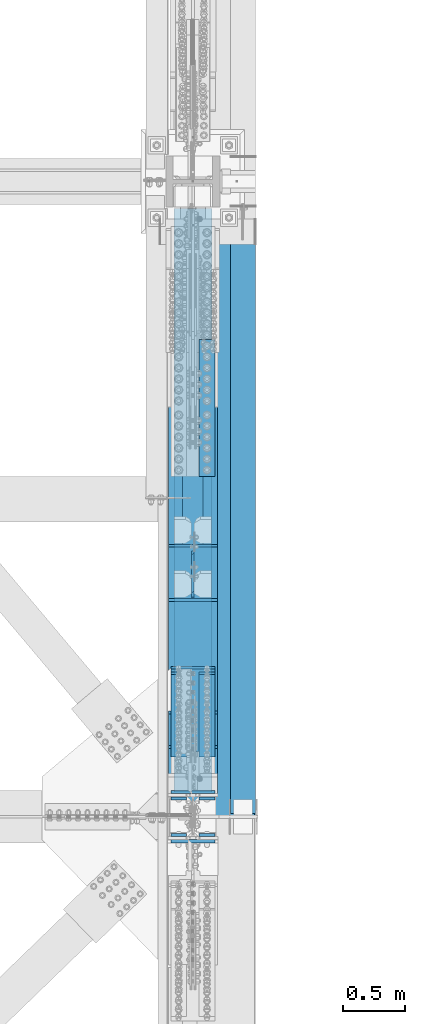
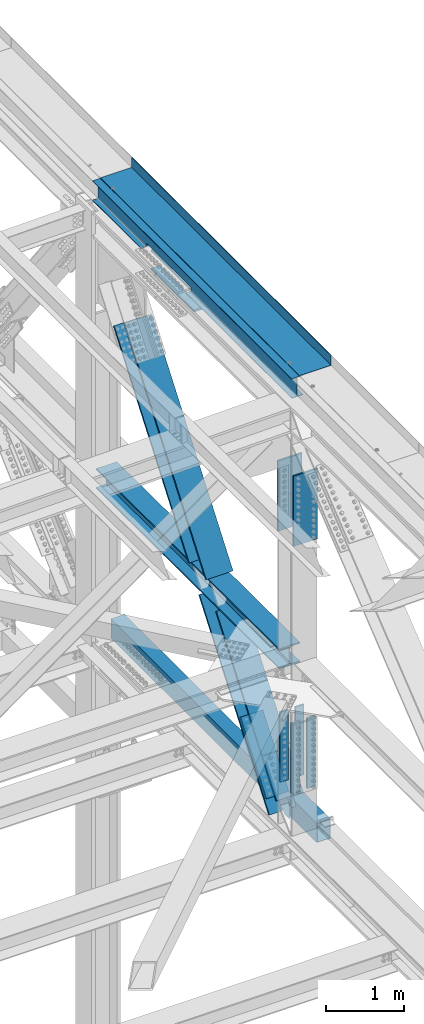
# One storey, part 1986 of 3843: 12 beams, 6 members, 8 elements without a shape of their own.
"""IFC2X3 building model written with IfcOpenShell, lengths in millimetres."""

from ifc_helpers import new_model, si_unit, frame, origin_with_axes, place, context, subcontext, project, spatial, faceted_brep, material, type_object, element, aggregate, save


model = new_model("IFC2X3")

# Units and contexts
model_context = context("Model", 3, precision=1e-05, world=origin_with_axes())
body_context = subcontext(model_context, "Body", "Model", "MODEL_VIEW")
ifc_project = project(units=[si_unit("LENGTHUNIT", "METRE", prefix="MILLI"), si_unit("AREAUNIT", "SQUARE_METRE"), si_unit("VOLUMEUNIT", "CUBIC_METRE"), si_unit("MASSUNIT", "GRAM", prefix="KILO"), si_unit("TIMEUNIT", "SECOND"), si_unit("PLANEANGLEUNIT", "RADIAN"), si_unit("SOLIDANGLEUNIT", "STERADIAN"), si_unit("THERMODYNAMICTEMPERATUREUNIT", "DEGREE_CELSIUS"), si_unit("LUMINOUSINTENSITYUNIT", "LUMEN")], contexts=[model_context])

# Site, building, storey
site_placement = place(None, origin_with_axes())
site = spatial("IfcSite", under=ifc_project, at=site_placement, CompositionType="ELEMENT")
building_placement = place(site_placement, origin_with_axes())
building = spatial("IfcBuilding", under=site, at=building_placement, Name="Undefined", CompositionType="ELEMENT")
storey_placement = place(building_placement, origin_with_axes())
storey = spatial("IfcBuildingStorey", under=building, at=storey_placement, Name="Undefined", CompositionType="ELEMENT", Elevation=0.0)

# Assembly, beam
assembly_1_placement = place(storey_placement, origin_with_axes())
assembly_1 = element("IfcElementAssembly", 1, at=assembly_1_placement, inside=storey, Name="BEAM", AssemblyPlace="NOTDEFINED", PredefinedType="RIGID_FRAME")
ifc_material_1 = material(Name="STEEL/A992")
beam_type_1 = type_object("IfcBeamType", Name="W12X26", PredefinedType="NOTDEFINED")
beam_1_placement = place(assembly_1_placement, frame((85648.8000000029, 83985.1, 46612.1750000001), z_axis=(0.0, 0.0, 1.0), x_axis=(0.0, 1.0, 0.0)))
beam_1 = element("IfcBeam", 2, at=beam_1_placement, type_object=beam_type_1, material=ifc_material_1, Name="BEAM", ObjectType="W12X26", context=body_context, shape_type="Brep", body=[
    faceted_brep([(2724.15000000001, -3.17500000000291, -146.050000000003), (2724.15000000001, -82.5500000000029, -146.050000000003), (2724.15000000001, -82.5500000000029, -155.574999999997), (2724.15000000001, 82.5500000000029, -155.574999999997), (2724.15000000001, 82.5500000000029, -146.050000000003), (2724.15000000001, 3.17500000000291, -146.050000000003), (2724.15000000002, 3.17500000000291, -92.0750000001062), (2724.15000000002, -3.17500000000291, -92.0750000001062), (3879.85000000002, -3.17500000000291, -92.0750000001062), (3879.85000000002, 3.17500000000291, -92.0750000001062), (3879.85000000002, 3.17500000000291, -146.050000000003), (3879.85000000002, 82.5500000000029, -146.050000000003), (3879.85000000001, 82.5500000000029, -155.574999999997), (3879.85000000001, -82.5500000000029, -155.574999999997), (3879.85000000002, -82.5500000000029, -146.050000000003), (3879.85000000002, -3.17500000000291, -146.050000000003), (0.0, -82.5500000000029, 155.574999999997), (0.0, -82.5500000000029, 146.050000000003), (5130.8, -82.5500000000029, 146.050000000003), (5130.8, -82.5500000000029, 155.574999999997), (0.0, 82.5500000000029, 155.574999999997), (5130.8, 82.5500000000029, 155.574999999997), (0.0, 82.5500000000029, 146.050000000003), (5130.8, 82.5500000000029, 146.050000000003), (0.0, 3.17500000000291, 146.050000000003), (5130.8, 3.17500000000291, 146.050000000003), (0.0, -82.5500000000029, -155.574999999997), (0.0, -82.5500000000029, -146.050000000003), (0.0, -3.17500000000291, -146.050000000003), (0.0, -3.17500000000291, 146.050000000003), (0.0, 3.17500000000291, -146.050000000003), (0.0, 82.5500000000029, -146.050000000003), (0.0, 82.5500000000029, -155.574999999997), (5130.8, -3.17500000000291, 146.050000000003), (5130.8, 3.17500000000291, -146.050000000003), (5130.8, -3.17500000000291, -146.050000000003), (5130.8, -82.5500000000029, -146.050000000003), (5130.8, -82.5500000000029, -155.574999999997), (5130.8, 82.5500000000029, -155.574999999997), (5130.8, 82.5500000000029, -146.050000000003)], [[[0, 1, 2, 3, 4, 5, 6, 7]], [[8, 9, 10, 11, 12, 13, 14, 15]], [[7, 6, 9, 8]], [[16, 17, 18, 19]], [[20, 16, 19, 21]], [[22, 20, 21, 23]], [[24, 22, 23, 25]], [[26, 27, 28, 29, 17, 16, 20, 22, 24, 30, 31, 32]], [[17, 29, 33, 18]], [[34, 25, 23, 21, 19, 18, 33, 35, 36, 37, 38, 39]], [[36, 35, 15, 14]], [[37, 36, 14, 13]], [[38, 37, 13, 12]], [[39, 38, 12, 11]], [[34, 39, 11, 10]], [[5, 30, 24, 25, 34, 10, 9, 6]], [[31, 30, 5, 4]], [[32, 31, 4, 3]], [[26, 32, 3, 2]], [[27, 26, 2, 1]], [[28, 27, 1, 0]], [[35, 33, 29, 28, 0, 7, 8, 15]]]),
])

assembly_2_placement = place(storey_placement, origin_with_axes())
assembly_2 = element("IfcElementAssembly", 3, at=assembly_2_placement, inside=storey, Name="BEAM", AssemblyPlace="NOTDEFINED", PredefinedType="RIGID_FRAME")
ifc_material_2 = material()
beam_type_2 = type_object("IfcBeamType", Name="HSS12X8X3/8", PredefinedType="NOTDEFINED")
beam_2_placement = place(assembly_2_placement, frame((86055.2000000001, 89319.1000000233, 39477.9500004064), z_axis=(0.0, 0.0, 1.0), x_axis=(0.0, -1.0, 0.0)))
beam_2 = element("IfcBeam", 4, at=beam_2_placement, type_object=beam_type_2, material=ifc_material_2, Name="BEAM", ObjectType="HSS12X8X3/8", context=body_context, shape_type="Brep", body=[
    faceted_brep([(6.35000000002037, 92.0749999999971, -142.875), (6.35000000002037, -92.0749999999971, -142.875), (5308.60000038189, -92.0749999999971, -142.875), (5308.60000038189, 92.0749999999971, -142.875), (6.35000000002037, -92.0749999999971, 142.875), (5308.60000038189, -92.0749999999971, 142.875), (6.35000000002037, 92.0749999999971, 142.875), (5308.60000038189, 92.0749999999971, 142.875), (6.35000000002037, 101.600000000006, -152.400000000001), (6.35000000002037, 101.600000000006, 152.400000000001), (5308.60000038189, 101.600000000006, 152.400000000001), (5308.60000038189, 101.600000000006, -152.400000000001), (6.35000000002037, -101.600000000006, 152.400000000001), (5308.60000038189, -101.600000000006, 152.400000000001), (6.35000000002037, -101.600000000006, -152.400000000001), (5308.60000038189, -101.600000000006, -152.400000000001)], [[[0, 1, 2, 3]], [[1, 4, 5, 2]], [[4, 6, 7, 5]], [[6, 0, 3, 7]], [[8, 9, 10, 11]], [[9, 12, 13, 10]], [[12, 14, 15, 13]], [[14, 8, 11, 15]], [[13, 15, 11, 10], [5, 7, 3, 2]], [[14, 12, 9, 8], [6, 4, 1, 0]]]),
])
aggregate(assembly_2, [beam_2])

# Assembly, beams
assembly_3_placement = place(storey_placement, origin_with_axes())
assembly_3 = element("IfcElementAssembly", 5, at=assembly_3_placement, inside=storey, Name="COLUMN", AssemblyPlace="NOTDEFINED", PredefinedType="RIGID_FRAME")
ifc_material_3 = material(Name="STEEL/A572-50")
beam_type_3 = type_object("IfcBeamType", PredefinedType="NOTDEFINED")
beam_3_placement = place(assembly_3_placement, frame((85763.1, 86732.984456283, 46115.7277416579), z_axis=(-1.0, 0.0, 0.0), x_axis=(0.0, 0.999988750778627, -0.00474323899895545)))
beam_3 = element("IfcBeam", 6, at=beam_3_placement, type_object=beam_type_3, material=ifc_material_3, Name="PLATE", context=body_context, shape_type="Brep", body=[
    faceted_brep([(8.73114913702011e-11, 15.8750000000073, -63.5), (8.73114913702011e-11, 15.8750000000073, 63.5), (1104.89999997285, 15.8750000015862, 63.5), (1104.89999997285, 15.8750000015862, -63.5), (-1.01863406598568e-10, -15.8750000000146, 63.5), (1104.89999997268, -15.8749999984284, 63.5), (-1.01863406598568e-10, -15.8750000000146, -63.5), (1104.89999997268, -15.8749999984284, -63.5)], [[[0, 1, 2, 3]], [[1, 4, 5, 2]], [[4, 6, 7, 5]], [[6, 0, 3, 7]], [[5, 7, 3, 2]], [[6, 4, 1, 0]]]),
])
beam_4_placement = place(assembly_3_placement, frame((85763.1, 86734.354633894, 46404.5940936941), z_axis=(-1.0, 0.0, 0.0), x_axis=(0.0, 0.999988750778627, -0.00474323899895545)))
beam_4 = element("IfcBeam", 7, at=beam_4_placement, type_object=beam_type_3, material=ifc_material_3, Name="PLATE", context=body_context, shape_type="Brep", body=[
    faceted_brep([(8.73114913702011e-11, 15.8750000000073, -63.5), (8.73114913702011e-11, 15.8750000000073, 63.5), (1104.89999997285, 15.8750000015862, 63.5), (1104.89999997285, 15.8750000015862, -63.5), (-1.01863406598568e-10, -15.8750000000146, 63.5), (1104.89999997268, -15.8749999984284, 63.5), (-1.01863406598568e-10, -15.8750000000146, -63.5), (1104.89999997268, -15.8749999984284, -63.5)], [[[0, 1, 2, 3]], [[1, 4, 5, 2]], [[4, 6, 7, 5]], [[6, 0, 3, 7]], [[5, 7, 3, 2]], [[6, 4, 1, 0]]]),
])
aggregate(assembly_3, [beam_3, beam_4])

# Assembly, members, beams
assembly_4_placement = place(storey_placement, origin_with_axes())
assembly_4 = element("IfcElementAssembly", 8, at=assembly_4_placement, inside=storey, Name="BEAM", AssemblyPlace="NOTDEFINED", PredefinedType="RIGID_FRAME")
member_type_1 = type_object("IfcMemberType", PredefinedType="NOTDEFINED")
member_1_placement = place(assembly_4_placement, frame((85534.5, 85144.65330628, 40781.2415149889), z_axis=(1.0, 0.0, 0.0), x_axis=(0.0, -0.605220451019692, -0.796057916025914)))
member_1 = element("IfcMember", 9, at=member_1_placement, type_object=member_type_1, material=ifc_material_3, Name="PLATE", context=body_context, shape_type="Brep", body=[
    faceted_brep([(-4.36557456851006e-11, 12.7000000000116, -63.5), (-4.36557456851006e-11, 12.7000000000116, 63.5), (1104.90000001677, 12.7000000017251, 63.5), (1104.90000001677, 12.7000000017251, -63.5), (1.45519152283669e-11, -12.700000000008, 63.5), (1104.90000001682, -12.6999999982909, 63.5), (1.45519152283669e-11, -12.700000000008, -63.5), (1104.90000001682, -12.6999999982909, -63.5)], [[[0, 1, 2, 3]], [[1, 4, 5, 2]], [[4, 6, 7, 5]], [[6, 0, 3, 7]], [[5, 7, 3, 2]], [[6, 4, 1, 0]]]),
])
member_2_placement = place(assembly_4_placement, frame((85763.1, 85144.65330628, 40781.2415149889), z_axis=(1.0, 0.0, 0.0), x_axis=(0.0, -0.605220451019692, -0.796057916025914)))
member_2 = element("IfcMember", 10, at=member_2_placement, type_object=member_type_1, material=ifc_material_3, Name="PLATE", context=body_context, shape_type="Brep", body=[
    faceted_brep([(-4.36557456851006e-11, 12.7000000000116, -63.5), (-4.36557456851006e-11, 12.7000000000116, 63.5), (1104.90000001677, 12.7000000017251, 63.5), (1104.90000001677, 12.7000000017251, -63.5), (1.45519152283669e-11, -12.700000000008, 63.5), (1104.90000001682, -12.6999999982909, 63.5), (1.45519152283669e-11, -12.700000000008, -63.5), (1104.90000001682, -12.6999999982909, -63.5)], [[[0, 1, 2, 3]], [[1, 4, 5, 2]], [[4, 6, 7, 5]], [[6, 0, 3, 7]], [[5, 7, 3, 2]], [[6, 4, 1, 0]]]),
])
member_type_2 = type_object("IfcMemberType", PredefinedType="NOTDEFINED")
member_3_placement = place(assembly_4_placement, frame((85648.8, 84520.1761979037, 39868.0495622531), z_axis=(1.0, 0.0, 0.0), x_axis=(0.0, 0.605220451019692, 0.796057916025914)))
member_3 = element("IfcMember", 11, at=member_3_placement, type_object=member_type_2, material=ifc_material_3, Name="PLATE", context=body_context, shape_type="Brep", body=[
    faceted_brep([(-1.45519152283669e-11, 12.7000000000025, -177.800000000003), (-1.45519152283669e-11, 12.7000000000025, 177.800000000003), (1104.90000001682, 12.7000000017051, 177.800000000003), (1104.90000001682, 12.7000000017051, -177.800000000003), (4.36557456851006e-11, -12.7000000000171, 177.800000000003), (1104.90000001686, -12.6999999983072, 177.800000000003), (4.36557456851006e-11, -12.7000000000171, -177.800000000003), (1104.90000001686, -12.6999999983072, -177.800000000003)], [[[0, 1, 2, 3]], [[1, 4, 5, 2]], [[4, 6, 7, 5]], [[6, 0, 3, 7]], [[5, 7, 3, 2]], [[6, 4, 1, 0]]]),
])
beam_type_4 = type_object("IfcBeamType", PredefinedType="NOTDEFINED")
beam_5_placement = place(assembly_4_placement, frame((85763.1, 83837.462692029, 41479.6131557466), z_axis=(-1.0, 0.0, 0.0), x_axis=(0.0, 0.0, -1.0)))
beam_5 = element("IfcBeam", 12, at=beam_5_placement, type_object=beam_type_4, material=ifc_material_3, Name="PLATE", context=body_context, shape_type="Brep", body=[
    faceted_brep([(-4.36557456851006e-11, 12.7000000000116, -63.5), (-4.36557456851006e-11, 12.7000000000116, 63.5), (1104.90000001677, 12.7000000017251, 63.5), (1104.90000001677, 12.7000000017251, -63.5), (1.45519152283669e-11, -12.700000000008, 63.5), (1104.90000001682, -12.6999999982909, 63.5), (1.45519152283669e-11, -12.700000000008, -63.5), (1104.90000001682, -12.6999999982909, -63.5)], [[[0, 1, 2, 3]], [[1, 4, 5, 2]], [[4, 6, 7, 5]], [[6, 0, 3, 7]], [[5, 7, 3, 2]], [[6, 4, 1, 0]]]),
])
beam_6_placement = place(assembly_4_placement, frame((85763.1, 84132.7376189964, 41479.613127104), z_axis=(-1.0, 0.0, 0.0), x_axis=(0.0, 0.0, -1.0)))
beam_6 = element("IfcBeam", 13, at=beam_6_placement, type_object=beam_type_4, material=ifc_material_3, Name="PLATE", context=body_context, shape_type="Brep", body=[
    faceted_brep([(-4.36557456851006e-11, 12.7000000000116, -63.5), (-4.36557456851006e-11, 12.7000000000116, 63.5), (1104.90000001677, 12.7000000017251, 63.5), (1104.90000001677, 12.7000000017251, -63.5), (1.45519152283669e-11, -12.700000000008, 63.5), (1104.90000001682, -12.6999999982909, 63.5), (1.45519152283669e-11, -12.700000000008, -63.5), (1104.90000001682, -12.6999999982909, -63.5)], [[[0, 1, 2, 3]], [[1, 4, 5, 2]], [[4, 6, 7, 5]], [[6, 0, 3, 7]], [[5, 7, 3, 2]], [[6, 4, 1, 0]]]),
])
beam_7_placement = place(assembly_4_placement, frame((85534.5, 83837.462692029, 41479.6131557466), z_axis=(-1.0, 0.0, 0.0), x_axis=(0.0, 0.0, -1.0)))
beam_7 = element("IfcBeam", 14, at=beam_7_placement, type_object=beam_type_4, material=ifc_material_3, Name="PLATE", context=body_context, shape_type="Brep", body=[
    faceted_brep([(-4.36557456851006e-11, 12.7000000000116, -63.5), (-4.36557456851006e-11, 12.7000000000116, 63.5), (1104.90000001677, 12.7000000017251, 63.5), (1104.90000001677, 12.7000000017251, -63.5), (1.45519152283669e-11, -12.700000000008, 63.5), (1104.90000001682, -12.6999999982909, 63.5), (1.45519152283669e-11, -12.700000000008, -63.5), (1104.90000001682, -12.6999999982909, -63.5)], [[[0, 1, 2, 3]], [[1, 4, 5, 2]], [[4, 6, 7, 5]], [[6, 0, 3, 7]], [[5, 7, 3, 2]], [[6, 4, 1, 0]]]),
])
beam_8_placement = place(assembly_4_placement, frame((85534.5, 84132.7376189964, 41479.613127104), z_axis=(-1.0, 0.0, 0.0), x_axis=(0.0, 0.0, -1.0)))
beam_8 = element("IfcBeam", 15, at=beam_8_placement, type_object=beam_type_4, material=ifc_material_3, Name="PLATE", context=body_context, shape_type="Brep", body=[
    faceted_brep([(-4.36557456851006e-11, 12.7000000000116, -63.5), (-4.36557456851006e-11, 12.7000000000116, 63.5), (1104.90000001677, 12.7000000017251, 63.5), (1104.90000001677, 12.7000000017251, -63.5), (1.45519152283669e-11, -12.700000000008, 63.5), (1104.90000001682, -12.6999999982909, 63.5), (1.45519152283669e-11, -12.700000000008, -63.5), (1104.90000001682, -12.6999999982909, -63.5)], [[[0, 1, 2, 3]], [[1, 4, 5, 2]], [[4, 6, 7, 5]], [[6, 0, 3, 7]], [[5, 7, 3, 2]], [[6, 4, 1, 0]]]),
])

# Assembly, beams
assembly_5_placement = place(storey_placement, origin_with_axes())
assembly_5 = element("IfcElementAssembly", 16, at=assembly_5_placement, inside=storey, Name="BEAM", AssemblyPlace="NOTDEFINED", PredefinedType="RIGID_FRAME")
beam_type_5 = type_object("IfcBeamType", PredefinedType="NOTDEFINED")
beam_9_placement = place(assembly_5_placement, frame((85648.8, 83786.6625000003, 45397.5980310956), z_axis=(1.0, 0.0, 0.0), x_axis=(0.0, 0.0, -1.0)))
beam_9 = element("IfcBeam", 17, at=beam_9_placement, type_object=beam_type_5, material=ifc_material_3, Name="PLATE", context=body_context, shape_type="Brep", body=[
    faceted_brep([(-1.45519152283669e-11, 12.7000000000025, -177.800000000003), (-1.45519152283669e-11, 12.7000000000025, 177.800000000003), (1104.90000001682, 12.7000000017051, 177.800000000003), (1104.90000001682, 12.7000000017051, -177.800000000003), (4.36557456851006e-11, -12.7000000000171, 177.800000000003), (1104.90000001686, -12.6999999983072, 177.800000000003), (4.36557456851006e-11, -12.7000000000171, -177.800000000003), (1104.90000001686, -12.6999999983072, -177.800000000003)], [[[0, 1, 2, 3]], [[1, 4, 5, 2]], [[4, 6, 7, 5]], [[6, 0, 3, 7]], [[5, 7, 3, 2]], [[6, 4, 1, 0]]]),
])
beam_10_placement = place(assembly_5_placement, frame((85648.8, 84183.5375000118, 45397.5980310956), z_axis=(1.0, 0.0, 0.0), x_axis=(0.0, 0.0, -1.0)))
beam_10 = element("IfcBeam", 18, at=beam_10_placement, type_object=beam_type_5, material=ifc_material_3, Name="PLATE", context=body_context, shape_type="Brep", body=[
    faceted_brep([(-1.45519152283669e-11, 12.7000000000025, -177.800000000003), (-1.45519152283669e-11, 12.7000000000025, 177.800000000003), (1104.90000001682, 12.7000000017051, 177.800000000003), (1104.90000001682, 12.7000000017051, -177.800000000003), (4.36557456851006e-11, -12.7000000000171, 177.800000000003), (1104.90000001686, -12.6999999983072, 177.800000000003), (4.36557456851006e-11, -12.7000000000171, -177.800000000003), (1104.90000001686, -12.6999999983072, -177.800000000003)], [[[0, 1, 2, 3]], [[1, 4, 5, 2]], [[4, 6, 7, 5]], [[6, 0, 3, 7]], [[5, 7, 3, 2]], [[6, 4, 1, 0]]]),
])
aggregate(assembly_5, [beam_9, beam_10])

# Assembly, member
assembly_6_placement = place(storey_placement, origin_with_axes())
assembly_6 = element("IfcElementAssembly", 19, at=assembly_6_placement, inside=storey, Name="V. BRACE", AssemblyPlace="NOTDEFINED", PredefinedType="RIGID_FRAME")
member_type_3 = type_object("IfcMemberType", Name="W14X159", PredefinedType="NOTDEFINED")
member_4_placement = place(assembly_6_placement, frame((85648.8, 84692.7712675286, 40430.8125536112), z_axis=(0.0, -0.796057916025909, 0.605220451019698), x_axis=(0.0, 0.605220451019692, 0.796057916025914)))
member_4 = element("IfcMember", 20, at=member_4_placement, type_object=member_type_3, material=ifc_material_1, Name="V. BRACE", ObjectType="W14X159", context=body_context, shape_type="Brep", body=[
    faceted_brep([(2216.51898587827, -198.4375, -160.337505577176), (2216.51898792338, -198.4375, -190.499999997424), (2216.51898792338, 198.4375, -190.499999997424), (2216.51898587827, 198.4375, -160.337499997389), (2216.51898587827, 9.52499999999418, -160.337499997389), (2216.51898587827, -9.52499999999418, -160.33750494507), (1921.91877837267, 9.52499999999418, 160.337500002788), (6.34999999323918, 9.52499999999418, 160.337499999503), (6.34999999323918, 198.4375, 160.337499999503), (1921.91877837267, 198.4375, 160.337500002788), (1953.79543739048, 198.4375, 160.337500002825), (1953.79543739048, 9.52499999999418, 160.337500002825), (2165.71898587717, -9.52499999999418, -160.33749999744), (2165.71898587717, 9.52499999999418, -160.33749999744), (2148.37322655409, 9.52500024769688, -137.522306666513), (2148.37322655409, -9.52500000753207, -137.522306666513), (2146.47397907326, 9.52500024808978, -132.664781957996), (2146.47397907326, -9.52500000751752, -132.664781957996), (2147.41767368457, 9.52500024918118, -127.535247108899), (2147.41767368457, -9.52500000748842, -127.535247108899), (2150.92135800864, 9.52500025066547, -123.671714600365), (2150.92135800864, -9.52500000744476, -123.671714600365), (2155.93450594929, 9.52500025209156, -122.23260549664), (2155.93450594929, -9.5250000074011, -122.23260549664), (2187.7862577316, -9.52500008967763, -122.16180728731), (2163.97914469577, 9.52500044213957, -122.214724344565), (1979.7514455374, 9.52500066497305, 122.440016041743), (2003.65120365832, -9.52499986696057, 122.369900247009), (1927.63438812691, -9.52499999431893, 123.319637304914), (1924.54820041938, -9.52499999433348, 125.397968494013), (1922.49370009138, -9.52499999431893, 128.500071570961), (1921.78438772046, -9.52499999428983, 132.152590025158), (1921.91877837267, -9.52499999999418, 160.337500002788), (6.34999999323918, -9.52499999999418, 160.337499999503), (6.34999999470892, -9.52499999999418, -160.337499999619), (1931.28133526347, -9.52499999428983, 122.582214983027), (1921.91877837267, -198.4375, 160.337500002788), (6.34999999323918, -198.4375, 160.337499999503), (1953.79543739048, -9.52499999999418, 160.337500002825), (1953.79543739048, -198.4375, 160.337500002825), (6.34999999309366, -198.4375, 190.499999999422), (1953.79543541165, -198.4375, 190.499976563988), (6.34999999309366, 198.4375, 190.499999999422), (1953.79543541165, 198.4375, 190.500000002881), (1921.78438772046, 9.52500026060443, 132.152590025158), (1922.49370009138, 9.52500026022608, 128.500071570961), (1924.54820041938, 9.52500026024063, 125.397968494013), (1927.63438812691, 9.52500026064808, 123.319637304914), (1931.28133526347, 9.52500026136113, 122.582214983027), (6.34999999470892, 9.52499999999418, -160.337499999619), (6.34999999483989, -198.4375, -190.499999999538), (6.34999999470892, -198.4375, -160.337499999619), (6.34999999470892, 198.4375, -160.337499999619), (6.34999999483989, 198.4375, -190.499999999538), (2165.71898587717, -198.4375, -160.33749999744), (2165.71898587717, 198.4375, -160.33749999744)], [[[0, 1, 2, 3, 4, 5]], [[6, 7, 8, 9, 10, 11]], [[12, 13, 14, 15]], [[15, 14, 16, 17]], [[17, 16, 18, 19]], [[19, 18, 20, 21]], [[21, 20, 22, 23]], [[24, 23, 22, 25]], [[24, 25, 26, 27]], [[28, 29, 30, 31, 32, 33, 34, 12, 15, 17, 19, 21, 23, 24, 27, 35]], [[36, 37, 33, 32, 38, 39]], [[40, 37, 36, 39, 41]], [[42, 40, 41, 43]], [[9, 8, 42, 43, 10]], [[41, 39, 38, 11, 10, 43]], [[32, 6, 11, 38]], [[31, 44, 6, 32]], [[30, 45, 44, 31]], [[29, 46, 45, 30]], [[28, 47, 46, 29]], [[35, 48, 47, 28]], [[27, 26, 48, 35]], [[25, 22, 20, 18, 16, 14, 13, 49, 7, 6, 44, 45, 46, 47, 48, 26]], [[50, 51, 34, 33, 37, 40, 42, 8, 7, 49, 52, 53]], [[12, 34, 51, 54, 0, 5]], [[13, 12, 5, 4]], [[55, 52, 49, 13, 4, 3]], [[53, 52, 55, 3, 2]], [[50, 53, 2, 1]], [[54, 51, 50, 1, 0]]]),
])
aggregate(assembly_6, [member_4])

assembly_7_placement = place(storey_placement, origin_with_axes())
assembly_7 = element("IfcElementAssembly", 21, at=assembly_7_placement, inside=storey, Name="V. BRACE", AssemblyPlace="NOTDEFINED", PredefinedType="RIGID_FRAME")
member_5_placement = place(assembly_7_placement, frame((85648.8, 86083.8681444708, 42260.54860778), z_axis=(0.0, -0.796057916025909, 0.605220451019698), x_axis=(0.0, 0.605220451019692, 0.796057916025914)))
member_5 = element("IfcMember", 22, at=member_5_placement, type_object=member_type_3, material=ifc_material_1, Name="V. BRACE", ObjectType="W14X159", context=body_context, shape_type="Brep", body=[
    faceted_brep([(346.147679184418, -198.4375, -160.337476070046), (346.147679184418, -9.52499999999418, -160.337499999827), (346.147679184418, 9.52499999999418, -160.337499999827), (346.147679184418, 198.4375, -160.337499999827), (346.147699241148, 198.4375, -190.499999999884), (346.147699241148, -198.4375, -190.499999999884), (132.098386285114, 198.4375, 160.337500000453), (3549.85244767601, 198.4375, 160.337500004905), (3549.85244767601, 9.52499999999418, 160.337500004905), (132.098386285114, 9.52499999999418, 160.337500000453), (81.9632190665288, 9.52499999999418, 160.33750000038), (81.9632190665288, 198.4375, 160.33750000038), (3549.85244767599, 198.4375, 190.500000004962), (81.758154095849, 198.4375, 190.500000000429), (3549.85244767599, -198.4375, 190.500000004962), (81.758154095849, -198.4375, 190.496298616927), (132.098386285114, -198.4375, 160.337500000453), (3549.85244767601, -198.4375, 160.337500004905), (81.9632190665288, -198.4375, 160.33750000038), (132.098386285114, -9.52499999999418, 160.337500000453), (3549.85244767601, -9.52499999999418, 160.337500004905), (81.9632190665288, -9.52499999999418, 160.33750000038), (149.591664698572, 9.52500025652989, 137.51508667232), (149.591664698572, -9.52499999999418, 137.51508667232), (151.519125286926, 9.52500025690824, 132.63829633424), (151.519125286926, -9.52499999999418, 132.63829633424), (3549.85244767601, 9.52499999999418, -160.337499995636), (374.248942408507, 9.52499999999418, -160.33749999979), (391.805508776568, 9.52500023611356, -137.523687888744), (393.735538690235, 9.5250002353423, -132.653920581892), (392.798806802108, 9.52500023493485, -127.500069355847), (389.278624429804, 9.52500023503671, -123.620898676912), (384.239658548817, 9.52500023558969, -122.189650291497), (318.626834977593, 9.52500064445485, -122.308865874656), (134.491836521542, 9.52500042173779, 122.222767799874), (141.992705379351, 9.52500025960035, 122.186010390782), (147.041004904444, 9.52500025871268, 123.604763444098), (150.573353469983, 9.5250002577086, 127.480418476865), (391.805508776568, -9.52499999999418, -137.523687888744), (374.248942408507, -9.52499999999418, -160.33749999979), (393.735538690235, -9.52499999999418, -132.653920581892), (392.798806802108, -9.52499999999418, -127.500069355847), (389.278624429804, -9.52499999999418, -123.620898676912), (384.239658548817, -9.52499999999418, -122.189650291497), (294.831584718922, -9.52499999999418, -122.352100786396), (110.575777947059, -9.52499999999418, 122.339966535808), (141.992705379351, -9.52499999999418, 122.186010390782), (147.041004904444, -9.52499999999418, 123.604763444098), (150.573353469983, -9.52499999999418, 127.480418476865), (3549.85244767601, -9.52499999999418, -160.337499995636), (3549.85244767601, -198.4375, -160.337499995636), (3549.85244767599, -198.4375, -190.499999995693), (3549.85244767599, 198.4375, -190.499999995693), (3549.85244767601, 198.4375, -160.337499995636), (374.248942408507, -198.4375, -160.33749999979), (374.248942408507, 198.4375, -160.33749999979)], [[[0, 1, 2, 3, 4, 5]], [[6, 7, 8, 9, 10, 11]], [[12, 7, 6, 11, 13]], [[14, 12, 13, 15]], [[16, 17, 14, 15, 18]], [[19, 20, 17, 16, 18, 21]], [[15, 13, 11, 10, 21, 18]], [[9, 19, 21, 10]], [[19, 9, 22, 23]], [[23, 22, 24, 25]], [[9, 8, 26, 27, 28, 29, 30, 31, 32, 33, 34, 35, 36, 37, 24, 22]], [[38, 28, 27, 39]], [[40, 29, 28, 38]], [[41, 30, 29, 40]], [[42, 31, 30, 41]], [[43, 32, 31, 42]], [[44, 33, 32, 43]], [[33, 44, 45, 34]], [[46, 35, 34, 45]], [[47, 36, 35, 46]], [[48, 37, 36, 47]], [[25, 24, 37, 48]], [[47, 46, 45, 44, 43, 42, 41, 40, 38, 39, 49, 20, 19, 23, 25, 48]], [[26, 8, 7, 12, 14, 17, 20, 49, 50, 51, 52, 53]], [[51, 50, 54, 0, 5]], [[52, 51, 5, 4]], [[55, 53, 52, 4, 3]], [[27, 26, 53, 55, 3, 2]], [[39, 27, 2, 1]], [[54, 50, 49, 39, 1, 0]]]),
])
aggregate(assembly_7, [member_5])

# Member
member_6_placement = place(assembly_4_placement, frame((85648.8, 83985.1, 39499.9991392354), z_axis=(0.0, -0.796057916025909, 0.605220451019698), x_axis=(0.0, 0.605220451019692, 0.796057916025914)))
member_6 = element("IfcMember", 23, at=member_6_placement, type_object=member_type_3, material=ifc_material_1, Name="BEAM", ObjectType="W14X159", context=body_context, shape_type="Brep", body=[
    faceted_brep([(504.353232545924, -9.52499931106286, 122.208321417667), (472.858090968322, 9.52499999999418, 122.193871736279), (281.78000935915, 9.52499999999418, -23.0774001134414), (308.410438455234, -9.52498214221851, -26.7614540145587), (439.737521082119, 9.52499999999418, -122.233607568181), (439.737521082119, -9.52499999999418, -122.233607568181), (380.367847592686, -9.52488606578845, -122.242867962617), (356.51662614003, 9.52499999999418, -122.24658824112), (444.768649454752, 9.52499999999418, -123.669830137791), (444.768649454752, -9.52499999999418, -123.669830137791), (448.282164486984, 9.52499999999418, -127.546710338378), (448.282164486984, -9.52499999999418, -127.546710338378), (449.217919837043, 9.52499999999418, -132.694462264844), (449.217919837043, -9.52499999999418, -132.694462264844), (447.293566460707, 9.52499999999418, -137.559835020802), (447.293566460707, -9.52499999999418, -137.559835020802), (429.804150453696, 9.52499999999418, -160.337499999718), (429.804150453696, -9.52499999999418, -160.337499999718), (1162.92851057496, 9.52499999999418, -160.337499998772), (1162.92851057496, 198.4375, -160.337499998772), (429.804150453696, 198.4375, -160.337499999718), (407.579150754653, 198.4375, -160.337499999747), (407.579150754653, 9.52499999999418, -160.337499999747), (407.579150754653, -9.52499999999418, -160.337499999747), (429.804150453696, -198.4375, -160.337499999718), (1162.92851057496, -198.4375, -160.337499998772), (1162.92851057496, -9.52499999999418, -160.337499998772), (407.579150754653, -198.4375, -160.338624094889), (1162.92851057496, -198.4375, -190.499999998807), (407.583855470279, -198.4375, -190.499999999811), (1162.92851057496, 198.4375, -190.499999998807), (407.583855470279, 198.4375, -190.499999999811), (1162.92851057496, 9.52499999999418, 160.337500001799), (1162.92851057496, 198.4375, 160.337500001799), (1162.92851057496, 198.4375, 190.500000001848), (1162.92851057496, -198.4375, 190.500000001848), (1162.92851057496, -198.4375, 160.337500001799), (1162.92851057496, -9.52499999999418, 160.337500001799), (583.995674180173, 198.4375, 160.337500001049), (583.995674180173, 9.52499999999418, 160.337500001049), (561.770725847557, 9.52499999999418, 160.337500001013), (561.770725847557, 198.4375, 160.337500001013), (562.706604905092, 198.4375, 190.500000001062), (562.706604905092, -198.4375, 190.500000001062), (583.995674180173, -198.4375, 160.337500001049), (561.770725847557, -198.4375, 160.337500001013), (583.995674180173, -9.52499999999418, 160.337500001049), (561.770725847557, -9.52499999999418, 160.337500001013), (601.467433309983, 9.52499999999418, 137.570722501951), (601.467433309983, -9.52499999999418, 137.570722501951), (603.388327125518, 9.52499999999418, 132.707098086146), (603.388327125518, -9.52499999999418, 132.707098086146), (602.45218516048, 9.52499999999418, 127.56236157885), (602.45218516048, -9.52499999999418, 127.56236157885), (598.941160338189, 9.52499999999418, 123.687135107306), (598.941160338189, -9.52499999999418, 123.687135107306), (593.913474546425, 9.52499999999418, 122.249410833312), (593.913474546425, -9.52499999999418, 122.249410833312)], [[[0, 1, 2, 3]], [[4, 5, 6, 7]], [[5, 4, 8, 9]], [[9, 8, 10, 11]], [[11, 10, 12, 13]], [[13, 12, 14, 15]], [[15, 14, 16, 17]], [[16, 18, 19, 20, 21, 22]], [[17, 16, 22, 23]], [[24, 25, 26, 17, 23, 27]], [[28, 25, 24, 27, 29]], [[30, 28, 29, 31]], [[27, 23, 22, 21, 31, 29]], [[20, 19, 30, 31, 21]], [[18, 32, 33, 34, 35, 36, 37, 26, 25, 28, 30, 19]], [[38, 33, 32, 39, 40, 41]], [[34, 33, 38, 41, 42]], [[35, 34, 42, 43]], [[44, 36, 35, 43, 45]], [[46, 37, 36, 44, 45, 47]], [[43, 42, 41, 40, 47, 45]], [[39, 46, 47, 40]], [[46, 39, 48, 49]], [[49, 48, 50, 51]], [[51, 50, 52, 53]], [[53, 52, 54, 55]], [[55, 54, 56, 57]], [[6, 5, 9, 11, 13, 15, 17, 26, 37, 46, 49, 51, 53, 55, 57, 0, 3]], [[7, 6, 3, 2]], [[56, 54, 52, 50, 48, 39, 32, 18, 16, 14, 12, 10, 8, 4, 7, 2, 1]], [[57, 56, 1, 0]]]),
])

aggregate(assembly_4, [member_1, member_2, member_3, member_6, beam_5, beam_6, beam_7, beam_8])

# Assembly, beam
assembly_8_placement = place(storey_placement, origin_with_axes())
assembly_8 = element("IfcElementAssembly", 24, at=assembly_8_placement, inside=storey, Name="BEAM", AssemblyPlace="NOTDEFINED", PredefinedType="RIGID_FRAME")
beam_type_6 = type_object("IfcBeamType", Name="W12X87", PredefinedType="NOTDEFINED")
beam_11_placement = place(assembly_8_placement, frame((85648.8, 83984.4231277795, 42270.242720572), z_axis=(0.0, 0.00461741499853088, 0.999989339682545), x_axis=(0.0, 0.999989339682545, -0.00461741499853021)))
beam_11 = element("IfcBeam", 25, at=beam_11_placement, type_object=beam_type_6, material=ifc_material_1, Name="BEAM", ObjectType="W12X87", context=body_context, shape_type="Brep", body=[
    faceted_brep([(199.754320588734, 153.987500000003, -138.112499999661), (199.754320588734, 6.35000000000582, -138.112499999661), (4913.09197096144, 6.35000000000582, -138.112499994568), (4913.09197096144, 147.637499999983, -138.112499994568), (4913.09197096144, 153.987500000003, -138.112499994568), (198.478851867883, 6.35000000000582, 138.112500000097), (4911.81651190866, 6.35000000000582, 138.112500005198), (4911.92331642656, 6.35000000000582, 114.981943293045), (4912.98569126775, 6.35000000000582, -115.095603980699), (198.478851867883, 153.987500000003, 138.112500000097), (4911.81651190866, 153.987500000003, 138.112500005198), (4911.81651190866, 147.637499999983, 138.112500005198), (198.383558227812, 153.987500000003, 158.75000000008), (4911.72121899092, 153.987500000003, 158.750000005173), (198.383558227812, -153.987500000003, 158.75000000008), (4911.72121899092, -153.987500000003, 158.750000005173), (4911.72121899092, -147.637500000012, 158.750000005173), (4911.72121899092, 147.637499999983, 158.750000005173), (198.478851867883, -153.987500000003, 138.112500000097), (4911.81651190866, -153.987500000003, 138.112500005198), (198.478851867883, -6.35000000000582, 138.112500000097), (4911.81651190866, -6.35000000000582, 138.112500005198), (4911.81651190866, -147.637500000012, 138.112500005198), (199.754320588734, -6.35000000000582, -138.112499999661), (4913.09197096144, -6.35000000000582, -138.112499994568), (199.754320588734, -153.987500000003, -138.112499999661), (4913.09197096144, -153.987500000003, -138.112499994568), (4913.09197096144, -147.637500000012, -138.112499994568), (199.849614228791, -153.987500000003, -158.749999999643), (4913.18726387915, -153.987500000003, -158.74999999455), (199.849614228791, 153.987500000003, -158.749999999643), (4913.18726387915, 153.987500000003, -158.74999999455), (4913.18726387915, 147.637499999983, -158.74999999455), (4913.18726387915, -147.637500000012, -158.74999999455)], [[[0, 1, 2, 3, 4]], [[1, 5, 6, 7, 8, 2]], [[5, 9, 10, 11, 6]], [[9, 12, 13, 10]], [[12, 14, 15, 16, 17, 13]], [[14, 18, 19, 15]], [[18, 20, 21, 22, 19]], [[20, 23, 24, 21]], [[23, 25, 26, 27, 24]], [[25, 28, 29, 26]], [[28, 30, 31, 32, 33, 29]], [[3, 2, 8, 7, 6, 11, 10, 13, 17, 16, 15, 19, 22, 21, 24, 27, 26, 29, 33, 32, 31, 4]], [[30, 0, 4, 31]], [[28, 25, 23, 20, 18, 14, 12, 9, 5, 1, 0, 30]]]),
])
aggregate(assembly_8, [beam_11])

# Beam
ifc_material_4 = material(Name="STEEL/A36")
beam_type_7 = type_object("IfcBeamType", PredefinedType="NOTDEFINED")
beam_12_placement = place(assembly_1_placement, frame((85680.5500000028, 86550.5, 46772.5125000001), z_axis=(0.0, -1.0, 0.0), x_axis=(1.0, 0.0, 0.0)))
beam_12 = element("IfcBeam", 26, at=beam_12_placement, type_object=beam_type_7, material=ifc_material_4, Name="BENT_PLATE", context=body_context, shape_type="Brep", body=[
    faceted_brep([(466.724999999977, 4.76249999999709, -2562.22500004766), (469.899998426612, 1.58750004770263, -2565.4), (0.0, 1.58750004770263, -2565.4), (0.0, 4.76249999999709, -2562.22500004766), (466.724999999991, 160.337500000009, -2562.22500004766), (469.899998426627, 160.337500000009, -2565.4), (0.0, 4.76249999999709, 2565.4), (466.724999999977, 4.76249999999709, 2565.4), (0.0, -4.76249999999709, -2565.4), (0.0, -4.76249999999709, 2565.4), (476.249999999971, -4.76249999999709, -2565.4), (476.249999999971, -4.76249999999709, 2565.4), (466.724999999991, 160.337500000009, 2565.4), (476.249999999985, 160.337500000009, 2565.4), (476.249999999985, 160.337500000009, -2565.4)], [[[0, 1, 2, 3]], [[4, 5, 1, 0]], [[6, 7, 0, 3]], [[8, 9, 6, 3, 2]], [[9, 8, 10, 11]], [[7, 12, 4, 0]], [[7, 6, 9, 11, 13, 12]], [[11, 10, 14, 13]], [[5, 14, 10, 8, 2, 1]], [[12, 13, 14, 5, 4]]]),
])

aggregate(assembly_1, [beam_12, beam_1])

save(model, "model.ifc")
